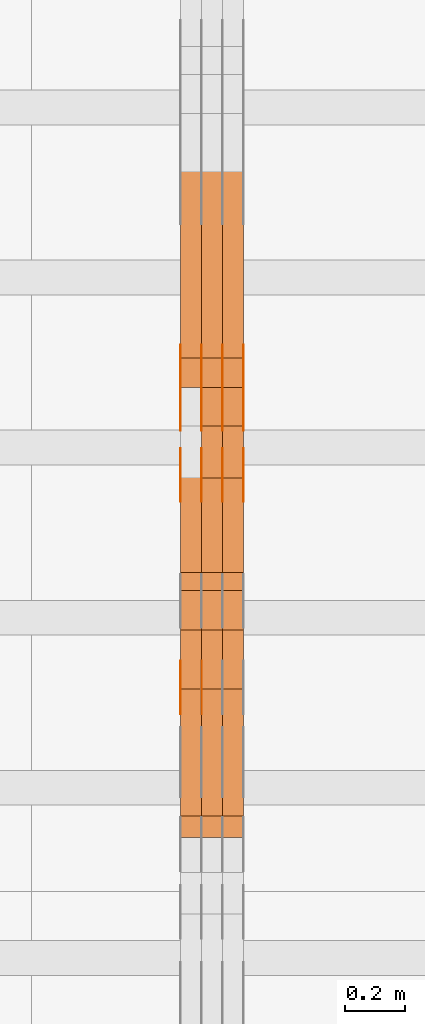
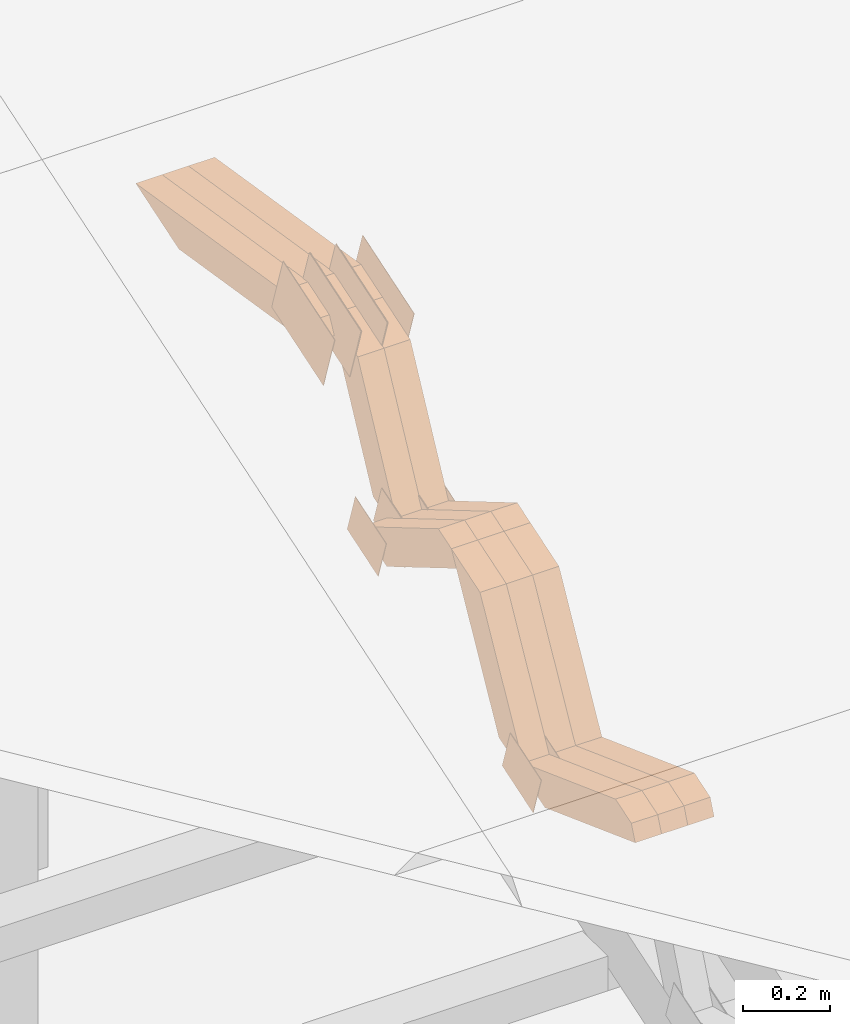
# One storey, part 117 of 385: 28 proxies.
"""IFC2X3 building model written with IfcOpenShell, lengths in millimetres."""

from ifc_helpers import new_model, entity, si_unit, converted_unit, derived_unit, direction, frame, origin, place, context, subcontext, project, spatial, polyline, outline, extrude, source, transform, mapped, material, type_object, type_shapes, element, save


model = new_model("IFC2X3")

# Units and contexts
model_context = context("Model", 3, precision=0.01, world=origin(), true_north=direction((6.12303176911189e-17, 1.0)))
body_context = subcontext(model_context, "Body", "Model", "MODEL_VIEW")
ifc_project = project(units=[si_unit("LENGTHUNIT", "METRE", prefix="MILLI"), si_unit("AREAUNIT", "SQUARE_METRE"), si_unit("VOLUMEUNIT", "CUBIC_METRE"), converted_unit("PLANEANGLEUNIT", "DEGREE", entity("IfcRatioMeasure", 0.0174532925199433), si_unit("PLANEANGLEUNIT", "RADIAN"), dimensions=[0, 0, 0, 0, 0, 0, 0]), si_unit("MASSUNIT", "GRAM", prefix="KILO"), derived_unit("MASSDENSITYUNIT", [(si_unit("MASSUNIT", "GRAM", prefix="KILO"), 1), (si_unit("LENGTHUNIT", "METRE"), -3)]), si_unit("TIMEUNIT", "SECOND"), si_unit("FREQUENCYUNIT", "HERTZ"), si_unit("THERMODYNAMICTEMPERATUREUNIT", "DEGREE_CELSIUS"), derived_unit("THERMALTRANSMITTANCEUNIT", [(si_unit("MASSUNIT", "GRAM", prefix="KILO"), 1), (si_unit("THERMODYNAMICTEMPERATUREUNIT", "KELVIN"), -1), (si_unit("TIMEUNIT", "SECOND"), -3)]), derived_unit("VOLUMETRICFLOWRATEUNIT", [(si_unit("LENGTHUNIT", "METRE"), 3), (si_unit("TIMEUNIT", "SECOND"), -1)]), si_unit("ELECTRICCURRENTUNIT", "AMPERE"), si_unit("ELECTRICVOLTAGEUNIT", "VOLT"), si_unit("POWERUNIT", "WATT"), si_unit("FORCEUNIT", "NEWTON", prefix="KILO"), si_unit("ILLUMINANCEUNIT", "LUX"), si_unit("LUMINOUSFLUXUNIT", "LUMEN"), si_unit("LUMINOUSINTENSITYUNIT", "CANDELA"), derived_unit("USERDEFINED", [(si_unit("MASSUNIT", "GRAM", prefix="KILO"), -1), (si_unit("LENGTHUNIT", "METRE"), -2), (si_unit("TIMEUNIT", "SECOND"), 3), (si_unit("LUMINOUSFLUXUNIT", "LUMEN"), 1)]), derived_unit("LINEARVELOCITYUNIT", [(si_unit("LENGTHUNIT", "METRE"), 1), (si_unit("TIMEUNIT", "SECOND"), -1)]), si_unit("PRESSUREUNIT", "PASCAL"), derived_unit("USERDEFINED", [(si_unit("LENGTHUNIT", "METRE"), -2), (si_unit("MASSUNIT", "GRAM", prefix="KILO"), 1), (si_unit("TIMEUNIT", "SECOND"), -2)])], contexts=[model_context])

# Site, building, storey
site_placement = place(None, origin())
site = spatial("IfcSite", under=ifc_project, at=site_placement, CompositionType="ELEMENT")
building_placement = place(site_placement, origin())
building = spatial("IfcBuilding", under=site, at=building_placement, CompositionType="ELEMENT")
storey_placement = place(building_placement, origin())
storey = spatial("IfcBuildingStorey", under=building, at=storey_placement, Name="Default", CompositionType="ELEMENT", Elevation=0.0)

# Proxies
ifc_material_1 = material(Name="IfcSurfaceStyle #244370")
building_element_proxy_type_1 = type_object("IfcBuildingElementProxyType", PredefinedType="NOTDEFINED", material=ifc_material_1)
shared_shape_1 = source(origin(), body_context, "Body", "SweptSolid", [
    extrude(outline(polyline([(-75.0008041947458, -59.9996998629349), (75.0007893252423, -59.9996998629349), (75.0008041947458, 59.9996998629349), (-75.0007893252423, 59.9996998629349), (-75.0008041947458, -59.9996998629349)])), frame((75.0008041947458, 60.0002282421692, 0.0), z_axis=(0.0, 0.0, 1.0), x_axis=(-1.0, 0.0, 0.0)), (0.0, 0.0, 1.0), 1.29999999999999),
])
type_shapes(building_element_proxy_type_1, [shared_shape_1])
proxy_1_placement = place(building_placement, frame((18246.3, 9291.048828125, 2194.94482421875), z_axis=(-1.0, 0.0, 0.0), x_axis=(0.0, 0.951056516295124, 0.309016994375039)))
element("IfcBuildingElementProxy", 1, at=proxy_1_placement, inside=storey, type_object=building_element_proxy_type_1, material=ifc_material_1, context=body_context, shape_type="MappedRepresentation", body=[
    mapped(shared_shape_1, transform((0.0, 0.0, 0.0), scale=1.0)),
])
ifc_material_2 = material(Name="IfcSurfaceStyle #244313")
building_element_proxy_type_2 = type_object("IfcBuildingElementProxyType", PredefinedType="NOTDEFINED", material=ifc_material_2)
shared_shape_2 = source(origin(), body_context, "Body", "SweptSolid", [
    extrude(outline(polyline([(-75.0008041947458, -59.9996998629349), (75.0007893252423, -59.9996998629349), (75.0008041947458, 59.9996998629349), (-75.0007893252423, 59.9996998629349), (-75.0008041947458, -59.9996998629349)])), frame((75.0008041947458, 60.0002282421692, 0.0), z_axis=(0.0, 0.0, 1.0), x_axis=(-1.0, 0.0, 0.0)), (0.0, 0.0, 1.0), 1.29999999999999),
])
type_shapes(building_element_proxy_type_2, [shared_shape_2])
proxy_2_placement = place(building_placement, frame((18175.0, 9291.048828125, 2194.94482421875), z_axis=(-1.0, 0.0, 0.0), x_axis=(0.0, 0.951056516295124, 0.309016994375039)))
element("IfcBuildingElementProxy", 2, at=proxy_2_placement, inside=storey, type_object=building_element_proxy_type_2, material=ifc_material_2, context=body_context, shape_type="MappedRepresentation", body=[
    mapped(shared_shape_2, transform((0.0, 0.0, 0.0), scale=1.0)),
])
ifc_material_3 = material(Name="IfcSurfaceStyle #244256")
building_element_proxy_type_3 = type_object("IfcBuildingElementProxyType", PredefinedType="NOTDEFINED", material=ifc_material_3)
shared_shape_3 = source(origin(), body_context, "Body", "SweptSolid", [
    extrude(outline(polyline([(-124.999432723313, -83.9999457831645), (125.000177551971, -83.9999457831645), (124.999395001513, 83.9999457831646), (-125.000139830171, 83.9999457831645), (-124.999432723313, -83.9999457831645)])), frame((125.000177551971, 84.0001194377192, 0.0), z_axis=(0.0, 0.0, 1.0), x_axis=(-1.0, 0.0, 0.0)), (0.0, 0.0, 1.0), 1.3),
])
type_shapes(building_element_proxy_type_3, [shared_shape_3])
proxy_3_placement = place(building_placement, frame((18386.3, 10242.0968435406, 2855.88278137571), z_axis=(-1.0, 0.0, 0.0), x_axis=(0.0, 0.951056516295154, 0.309016994374948)))
element("IfcBuildingElementProxy", 3, at=proxy_3_placement, inside=storey, type_object=building_element_proxy_type_3, material=ifc_material_3, context=body_context, shape_type="MappedRepresentation", body=[
    mapped(shared_shape_3, transform((0.0, 0.0, 0.0), scale=1.0)),
])
ifc_material_4 = material(Name="IfcSurfaceStyle #244199")
building_element_proxy_type_4 = type_object("IfcBuildingElementProxyType", PredefinedType="NOTDEFINED", material=ifc_material_4)
shared_shape_4 = source(origin(), body_context, "Body", "SweptSolid", [
    extrude(outline(polyline([(-124.999432723313, -83.9999457831645), (125.000177551971, -83.9999457831645), (124.999395001513, 83.9999457831646), (-125.000139830171, 83.9999457831645), (-124.999432723313, -83.9999457831645)])), frame((125.000177551971, 84.0001194377192, 0.0), z_axis=(0.0, 0.0, 1.0), x_axis=(-1.0, 0.0, 0.0)), (0.0, 0.0, 1.0), 1.3),
])
type_shapes(building_element_proxy_type_4, [shared_shape_4])
proxy_4_placement = place(building_placement, frame((18315.0, 10242.0968435406, 2855.88278137571), z_axis=(-1.0, 0.0, 0.0), x_axis=(0.0, 0.951056516295154, 0.309016994374948)))
element("IfcBuildingElementProxy", 4, at=proxy_4_placement, inside=storey, type_object=building_element_proxy_type_4, material=ifc_material_4, context=body_context, shape_type="MappedRepresentation", body=[
    mapped(shared_shape_4, transform((0.0, 0.0, 0.0), scale=1.0)),
])
ifc_material_5 = material(Name="IfcSurfaceStyle #244142")
building_element_proxy_type_5 = type_object("IfcBuildingElementProxyType", PredefinedType="NOTDEFINED", material=ifc_material_5)
shared_shape_5 = source(origin(), body_context, "Body", "SweptSolid", [
    extrude(outline(polyline([(-124.999432723313, -83.9999457831645), (125.000177551971, -83.9999457831645), (124.999395001513, 83.9999457831646), (-125.000139830171, 83.9999457831645), (-124.999432723313, -83.9999457831645)])), frame((125.000177551971, 84.0001194377192, 0.0), z_axis=(0.0, 0.0, 1.0), x_axis=(-1.0, 0.0, 0.0)), (0.0, 0.0, 1.0), 1.3),
])
type_shapes(building_element_proxy_type_5, [shared_shape_5])
proxy_5_placement = place(building_placement, frame((18316.3, 10242.0968435406, 2855.88278137571), z_axis=(-1.0, 0.0, 0.0), x_axis=(0.0, 0.951056516295154, 0.309016994374948)))
element("IfcBuildingElementProxy", 5, at=proxy_5_placement, inside=storey, type_object=building_element_proxy_type_5, material=ifc_material_5, context=body_context, shape_type="MappedRepresentation", body=[
    mapped(shared_shape_5, transform((0.0, 0.0, 0.0), scale=1.0)),
])
ifc_material_6 = material(Name="IfcSurfaceStyle #244085")
building_element_proxy_type_6 = type_object("IfcBuildingElementProxyType", PredefinedType="NOTDEFINED", material=ifc_material_6)
shared_shape_6 = source(origin(), body_context, "Body", "SweptSolid", [
    extrude(outline(polyline([(-124.999432723313, -83.9999457831645), (125.000177551971, -83.9999457831645), (124.999395001513, 83.9999457831646), (-125.000139830171, 83.9999457831645), (-124.999432723313, -83.9999457831645)])), frame((125.000177551971, 84.0001194377192, 0.0), z_axis=(0.0, 0.0, 1.0), x_axis=(-1.0, 0.0, 0.0)), (0.0, 0.0, 1.0), 1.29999999999998),
])
type_shapes(building_element_proxy_type_6, [shared_shape_6])
proxy_6_placement = place(building_placement, frame((18245.0, 10242.0968435406, 2855.88278137571), z_axis=(-1.0, 0.0, 0.0), x_axis=(0.0, 0.951056516295154, 0.309016994374948)))
element("IfcBuildingElementProxy", 6, at=proxy_6_placement, inside=storey, type_object=building_element_proxy_type_6, material=ifc_material_6, context=body_context, shape_type="MappedRepresentation", body=[
    mapped(shared_shape_6, transform((0.0, 0.0, 0.0), scale=1.0)),
])
ifc_material_7 = material(Name="IfcSurfaceStyle #244028")
building_element_proxy_type_7 = type_object("IfcBuildingElementProxyType", PredefinedType="NOTDEFINED", material=ifc_material_7)
shared_shape_7 = source(origin(), body_context, "Body", "SweptSolid", [
    extrude(outline(polyline([(-124.999432723313, -83.9999457831645), (125.000177551971, -83.9999457831645), (124.999395001513, 83.9999457831646), (-125.000139830171, 83.9999457831645), (-124.999432723313, -83.9999457831645)])), frame((125.000177551971, 84.0001194377192, 0.0), z_axis=(0.0, 0.0, 1.0), x_axis=(-1.0, 0.0, 0.0)), (0.0, 0.0, 1.0), 1.29999999999998),
])
type_shapes(building_element_proxy_type_7, [shared_shape_7])
proxy_7_placement = place(building_placement, frame((18246.3, 10242.0968435406, 2855.88278137571), z_axis=(-1.0, 0.0, 0.0), x_axis=(0.0, 0.951056516295154, 0.309016994374948)))
element("IfcBuildingElementProxy", 7, at=proxy_7_placement, inside=storey, type_object=building_element_proxy_type_7, material=ifc_material_7, context=body_context, shape_type="MappedRepresentation", body=[
    mapped(shared_shape_7, transform((0.0, 0.0, 0.0), scale=1.0)),
])
ifc_material_8 = material(Name="IfcSurfaceStyle #243971")
building_element_proxy_type_8 = type_object("IfcBuildingElementProxyType", PredefinedType="NOTDEFINED", material=ifc_material_8)
shared_shape_8 = source(origin(), body_context, "Body", "SweptSolid", [
    extrude(outline(polyline([(-124.999432723313, -83.9999457831645), (125.000177551971, -83.9999457831645), (124.999395001513, 83.9999457831646), (-125.000139830171, 83.9999457831645), (-124.999432723313, -83.9999457831645)])), frame((125.000177551971, 84.0001194377192, 0.0), z_axis=(0.0, 0.0, 1.0), x_axis=(-1.0, 0.0, 0.0)), (0.0, 0.0, 1.0), 1.29999999999998),
])
type_shapes(building_element_proxy_type_8, [shared_shape_8])
proxy_8_placement = place(building_placement, frame((18175.0, 10242.0968435406, 2855.88278137571), z_axis=(-1.0, 0.0, 0.0), x_axis=(0.0, 0.951056516295154, 0.309016994374948)))
element("IfcBuildingElementProxy", 8, at=proxy_8_placement, inside=storey, type_object=building_element_proxy_type_8, material=ifc_material_8, context=body_context, shape_type="MappedRepresentation", body=[
    mapped(shared_shape_8, transform((0.0, 0.0, 0.0), scale=1.0)),
])
ifc_material_9 = material(Name="IfcSurfaceStyle #242546")
building_element_proxy_type_9 = type_object("IfcBuildingElementProxyType", PredefinedType="NOTDEFINED", material=ifc_material_9)
shared_shape_9 = source(origin(), body_context, "Body", "SweptSolid", [
    extrude(outline(polyline([(-74.9998754286189, -60.0000016373433), (74.9998605591118, -60.0000016373433), (74.9998754286189, 60.0000016373433), (-74.9998605591118, 60.0000016373433), (-74.9998754286189, -60.0000016373433)])), frame((74.9999131819004, 60.0000016373433, 0.0), z_axis=(0.0, 0.0, 1.0), x_axis=(-1.0, 0.0, 0.0)), (0.0, 0.0, 1.0), 1.3),
])
type_shapes(building_element_proxy_type_9, [shared_shape_9])
proxy_9_placement = place(building_placement, frame((18386.3, 10004.8612689908, 2426.87628052724), z_axis=(-1.0, 0.0, 0.0), x_axis=(0.0, 0.951056516295124, 0.309016994375039)))
element("IfcBuildingElementProxy", 9, at=proxy_9_placement, inside=storey, type_object=building_element_proxy_type_9, material=ifc_material_9, context=body_context, shape_type="MappedRepresentation", body=[
    mapped(shared_shape_9, transform((0.0, 0.0, 0.0), scale=1.0)),
])
ifc_material_10 = material(Name="IfcSurfaceStyle #242489")
building_element_proxy_type_10 = type_object("IfcBuildingElementProxyType", PredefinedType="NOTDEFINED", material=ifc_material_10)
shared_shape_10 = source(origin(), body_context, "Body", "SweptSolid", [
    extrude(outline(polyline([(-74.9998754286189, -60.0000016373433), (74.9998605591118, -60.0000016373433), (74.9998754286189, 60.0000016373433), (-74.9998605591118, 60.0000016373433), (-74.9998754286189, -60.0000016373433)])), frame((74.9999131819004, 60.0000016373433, 0.0), z_axis=(0.0, 0.0, 1.0), x_axis=(-1.0, 0.0, 0.0)), (0.0, 0.0, 1.0), 1.3),
])
type_shapes(building_element_proxy_type_10, [shared_shape_10])
proxy_10_placement = place(building_placement, frame((18315.0, 10004.8612689908, 2426.87628052724), z_axis=(-1.0, 0.0, 0.0), x_axis=(0.0, 0.951056516295124, 0.309016994375039)))
element("IfcBuildingElementProxy", 10, at=proxy_10_placement, inside=storey, type_object=building_element_proxy_type_10, material=ifc_material_10, context=body_context, shape_type="MappedRepresentation", body=[
    mapped(shared_shape_10, transform((0.0, 0.0, 0.0), scale=1.0)),
])
ifc_material_11 = material(Name="IfcSurfaceStyle #242432")
building_element_proxy_type_11 = type_object("IfcBuildingElementProxyType", PredefinedType="NOTDEFINED", material=ifc_material_11)
shared_shape_11 = source(origin(), body_context, "Body", "SweptSolid", [
    extrude(outline(polyline([(-74.9998754286189, -60.0000016373433), (74.9998605591118, -60.0000016373433), (74.9998754286189, 60.0000016373433), (-74.9998605591118, 60.0000016373433), (-74.9998754286189, -60.0000016373433)])), frame((74.9999131819004, 60.0000016373433, 0.0), z_axis=(0.0, 0.0, 1.0), x_axis=(-1.0, 0.0, 0.0)), (0.0, 0.0, 1.0), 1.3),
])
type_shapes(building_element_proxy_type_11, [shared_shape_11])
proxy_11_placement = place(building_placement, frame((18316.3, 10004.8612689908, 2426.87628052724), z_axis=(-1.0, 0.0, 0.0), x_axis=(0.0, 0.951056516295124, 0.309016994375039)))
element("IfcBuildingElementProxy", 11, at=proxy_11_placement, inside=storey, type_object=building_element_proxy_type_11, material=ifc_material_11, context=body_context, shape_type="MappedRepresentation", body=[
    mapped(shared_shape_11, transform((0.0, 0.0, 0.0), scale=1.0)),
])
ifc_material_12 = material(Name="IfcSurfaceStyle #242375")
building_element_proxy_type_12 = type_object("IfcBuildingElementProxyType", PredefinedType="NOTDEFINED", material=ifc_material_12)
shared_shape_12 = source(origin(), body_context, "Body", "SweptSolid", [
    extrude(outline(polyline([(-74.9998754286189, -60.0000016373433), (74.9998605591118, -60.0000016373433), (74.9998754286189, 60.0000016373433), (-74.9998605591118, 60.0000016373433), (-74.9998754286189, -60.0000016373433)])), frame((74.9999131819004, 60.0000016373433, 0.0), z_axis=(0.0, 0.0, 1.0), x_axis=(-1.0, 0.0, 0.0)), (0.0, 0.0, 1.0), 1.29999999999999),
])
type_shapes(building_element_proxy_type_12, [shared_shape_12])
proxy_12_placement = place(building_placement, frame((18245.0, 10004.8612689908, 2426.87628052724), z_axis=(-1.0, 0.0, 0.0), x_axis=(0.0, 0.951056516295124, 0.309016994375039)))
element("IfcBuildingElementProxy", 12, at=proxy_12_placement, inside=storey, type_object=building_element_proxy_type_12, material=ifc_material_12, context=body_context, shape_type="MappedRepresentation", body=[
    mapped(shared_shape_12, transform((0.0, 0.0, 0.0), scale=1.0)),
])
ifc_material_13 = material(Name="IfcSurfaceStyle #242318")
building_element_proxy_type_13 = type_object("IfcBuildingElementProxyType", PredefinedType="NOTDEFINED", material=ifc_material_13)
shared_shape_13 = source(origin(), body_context, "Body", "SweptSolid", [
    extrude(outline(polyline([(-74.9998754286189, -60.0000016373433), (74.9998605591118, -60.0000016373433), (74.9998754286189, 60.0000016373433), (-74.9998605591118, 60.0000016373433), (-74.9998754286189, -60.0000016373433)])), frame((74.9999131819004, 60.0000016373433, 0.0), z_axis=(0.0, 0.0, 1.0), x_axis=(-1.0, 0.0, 0.0)), (0.0, 0.0, 1.0), 1.29999999999999),
])
type_shapes(building_element_proxy_type_13, [shared_shape_13])
proxy_13_placement = place(building_placement, frame((18246.3, 10004.8612689908, 2426.87628052724), z_axis=(-1.0, 0.0, 0.0), x_axis=(0.0, 0.951056516295124, 0.309016994375039)))
element("IfcBuildingElementProxy", 13, at=proxy_13_placement, inside=storey, type_object=building_element_proxy_type_13, material=ifc_material_13, context=body_context, shape_type="MappedRepresentation", body=[
    mapped(shared_shape_13, transform((0.0, 0.0, 0.0), scale=1.0)),
])
ifc_material_14 = material(Name="IfcSurfaceStyle #242261")
building_element_proxy_type_14 = type_object("IfcBuildingElementProxyType", PredefinedType="NOTDEFINED", material=ifc_material_14)
shared_shape_14 = source(origin(), body_context, "Body", "SweptSolid", [
    extrude(outline(polyline([(-74.9998754286189, -60.0000016373433), (74.9998605591118, -60.0000016373433), (74.9998754286189, 60.0000016373433), (-74.9998605591118, 60.0000016373433), (-74.9998754286189, -60.0000016373433)])), frame((74.9999131819004, 60.0000016373433, 0.0), z_axis=(0.0, 0.0, 1.0), x_axis=(-1.0, 0.0, 0.0)), (0.0, 0.0, 1.0), 1.29999999999999),
])
type_shapes(building_element_proxy_type_14, [shared_shape_14])
proxy_14_placement = place(building_placement, frame((18175.0, 10004.8612689908, 2426.87628052724), z_axis=(-1.0, 0.0, 0.0), x_axis=(0.0, 0.951056516295124, 0.309016994375039)))
element("IfcBuildingElementProxy", 14, at=proxy_14_placement, inside=storey, type_object=building_element_proxy_type_14, material=ifc_material_14, context=body_context, shape_type="MappedRepresentation", body=[
    mapped(shared_shape_14, transform((0.0, 0.0, 0.0), scale=1.0)),
])
ifc_material_15 = material(Name="IfcSurfaceStyle #222224")
building_element_proxy_type_15 = type_object("IfcBuildingElementProxyType", Name="T1-W5 222222", PredefinedType="NOTDEFINED", material=ifc_material_15)
shared_shape_15 = source(origin(), body_context, "Body", "SweptSolid", [
    extrude(outline(polyline([(-301.214270081322, -47.5000783565111), (303.980395954293, -47.5000783565111), (288.664123931657, 0.000197935560590153), (195.704076557203, 47.4999793887309), (-487.134326361831, 47.4999793887309), (-301.214270081322, -47.5000783565111)])), frame((303.980395954293, 47.5001815410909, 0.0), z_axis=(0.0, 0.0, 1.0), x_axis=(-1.0, 0.0, 0.0)), (0.0, 0.0, 1.0), 70.0),
])
type_shapes(building_element_proxy_type_15, [shared_shape_15])
proxy_15_placement = place(building_placement, frame((18385.0, 10379.2051671398, 2863.91176079486), z_axis=(-1.0, 0.0, 0.0), x_axis=(0.0, 0.987508363398486, -0.1575665961365)))
element("IfcBuildingElementProxy", 15, at=proxy_15_placement, inside=storey, type_object=building_element_proxy_type_15, material=ifc_material_15, Name="T1-W5", context=body_context, shape_type="MappedRepresentation", body=[
    mapped(shared_shape_15, transform((0.0, 0.0, 0.0), scale=1.0)),
])
ifc_material_16 = material(Name="IfcSurfaceStyle #222158")
building_element_proxy_type_16 = type_object("IfcBuildingElementProxyType", Name="T1-W5 222156", PredefinedType="NOTDEFINED", material=ifc_material_16)
shared_shape_16 = source(origin(), body_context, "Body", "SweptSolid", [
    extrude(outline(polyline([(-301.214270081322, -47.5000783565111), (303.980395954293, -47.5000783565111), (288.664123931657, 0.000197935560590153), (195.704076557203, 47.4999793887309), (-487.134326361831, 47.4999793887309), (-301.214270081322, -47.5000783565111)])), frame((303.980395954293, 47.5001815410909, 0.0), z_axis=(0.0, 0.0, 1.0), x_axis=(-1.0, 0.0, 0.0)), (0.0, 0.0, 1.0), 70.0),
])
type_shapes(building_element_proxy_type_16, [shared_shape_16])
proxy_16_placement = place(building_placement, frame((18315.0, 10379.2051671398, 2863.91176079486), z_axis=(-1.0, 0.0, 0.0), x_axis=(0.0, 0.987508363398486, -0.1575665961365)))
element("IfcBuildingElementProxy", 16, at=proxy_16_placement, inside=storey, type_object=building_element_proxy_type_16, material=ifc_material_16, Name="T1-W5", context=body_context, shape_type="MappedRepresentation", body=[
    mapped(shared_shape_16, transform((0.0, 0.0, 0.0), scale=1.0)),
])
ifc_material_17 = material(Name="IfcSurfaceStyle #222092")
building_element_proxy_type_17 = type_object("IfcBuildingElementProxyType", Name="T1-W5 222090", PredefinedType="NOTDEFINED", material=ifc_material_17)
shared_shape_17 = source(origin(), body_context, "Body", "SweptSolid", [
    extrude(outline(polyline([(-301.214270081322, -47.5000783565111), (303.980395954293, -47.5000783565111), (288.664123931657, 0.000197935560590153), (195.704076557203, 47.4999793887309), (-487.134326361831, 47.4999793887309), (-301.214270081322, -47.5000783565111)])), frame((303.980395954293, 47.5001815410909, 0.0), z_axis=(0.0, 0.0, 1.0), x_axis=(-1.0, 0.0, 0.0)), (0.0, 0.0, 1.0), 70.0),
])
type_shapes(building_element_proxy_type_17, [shared_shape_17])
proxy_17_placement = place(building_placement, frame((18245.0, 10379.2051671398, 2863.91176079486), z_axis=(-1.0, 0.0, 0.0), x_axis=(0.0, 0.987508363398486, -0.1575665961365)))
element("IfcBuildingElementProxy", 17, at=proxy_17_placement, inside=storey, type_object=building_element_proxy_type_17, material=ifc_material_17, Name="T1-W5", context=body_context, shape_type="MappedRepresentation", body=[
    mapped(shared_shape_17, transform((0.0, 0.0, 0.0), scale=1.0)),
])
ifc_material_18 = material(Name="IfcSurfaceStyle #221828")
building_element_proxy_type_18 = type_object("IfcBuildingElementProxyType", Name="T1-W37 221826", PredefinedType="NOTDEFINED", material=ifc_material_18)
shared_shape_18 = source(origin(), body_context, "Body", "SweptSolid", [
    extrude(outline(polyline([(111.787482004227, -179.289397746839), (245.990585035629, -179.289397746839), (-64.0177573255029, 131.410401861866), (-131.116409377007, 131.410958895698), (-162.643900337347, 95.757434736113), (111.787482004227, -179.289397746839)])), frame((185.635323570343, 47.5011799885346, 0.0), z_axis=(0.0, 0.0, 1.0), x_axis=(0.706316677358935, 0.707896003156279, 0.0)), (0.0, 0.0, 1.0), 70.0),
])
type_shapes(building_element_proxy_type_18, [shared_shape_18])
proxy_18_placement = place(building_placement, frame((18385.0, 10081.8581176196, 2424.08390440728), z_axis=(-1.0, 0.0, 0.0), x_axis=(0.0, 0.452995827831714, 0.891512635898707)))
element("IfcBuildingElementProxy", 18, at=proxy_18_placement, inside=storey, type_object=building_element_proxy_type_18, material=ifc_material_18, Name="T1-W37", context=body_context, shape_type="MappedRepresentation", body=[
    mapped(shared_shape_18, transform((0.0, 0.0, 0.0), scale=1.0)),
])
ifc_material_19 = material(Name="IfcSurfaceStyle #221762")
building_element_proxy_type_19 = type_object("IfcBuildingElementProxyType", Name="T1-W37 221760", PredefinedType="NOTDEFINED", material=ifc_material_19)
shared_shape_19 = source(origin(), body_context, "Body", "SweptSolid", [
    extrude(outline(polyline([(111.787482004227, -179.289397746839), (245.990585035629, -179.289397746839), (-64.0177573255029, 131.410401861866), (-131.116409377007, 131.410958895698), (-162.643900337347, 95.757434736113), (111.787482004227, -179.289397746839)])), frame((185.635323570343, 47.5011799885346, 0.0), z_axis=(0.0, 0.0, 1.0), x_axis=(0.706316677358935, 0.707896003156279, 0.0)), (0.0, 0.0, 1.0), 70.0),
])
type_shapes(building_element_proxy_type_19, [shared_shape_19])
proxy_19_placement = place(building_placement, frame((18315.0, 10081.8581176196, 2424.08390440728), z_axis=(-1.0, 0.0, 0.0), x_axis=(0.0, 0.452995827831714, 0.891512635898707)))
element("IfcBuildingElementProxy", 19, at=proxy_19_placement, inside=storey, type_object=building_element_proxy_type_19, material=ifc_material_19, Name="T1-W37", context=body_context, shape_type="MappedRepresentation", body=[
    mapped(shared_shape_19, transform((0.0, 0.0, 0.0), scale=1.0)),
])
ifc_material_20 = material(Name="IfcSurfaceStyle #221432")
building_element_proxy_type_20 = type_object("IfcBuildingElementProxyType", Name="T1-W43 221430", PredefinedType="NOTDEFINED", material=ifc_material_20)
shared_shape_20 = source(origin(), body_context, "Body", "SweptSolid", [
    extrude(outline(polyline([(-198.159905426436, -47.4999961988362), (173.155878681738, -47.4999961988362), (174.585865234707, -0.00038778214839239), (132.582704932703, 47.5001900899104), (-282.164543422712, 47.5001900899104), (-198.159905426436, -47.4999961988362)])), frame((174.585865234707, 47.5001900899104, 0.0), z_axis=(0.0, 0.0, 1.0), x_axis=(-1.0, 0.0, 0.0)), (0.0, 0.0, 1.0), 70.0),
])
type_shapes(building_element_proxy_type_20, [shared_shape_20])
proxy_20_placement = place(building_placement, frame((18385.0, 9730.71877771152, 2634.4881681647), z_axis=(-1.0, 0.0, 0.0), x_axis=(0.0, 0.861495156633645, -0.507765787639115)))
element("IfcBuildingElementProxy", 20, at=proxy_20_placement, inside=storey, type_object=building_element_proxy_type_20, material=ifc_material_20, Name="T1-W43", context=body_context, shape_type="MappedRepresentation", body=[
    mapped(shared_shape_20, transform((0.0, 0.0, 0.0), scale=1.0)),
])
ifc_material_21 = material(Name="IfcSurfaceStyle #221366")
building_element_proxy_type_21 = type_object("IfcBuildingElementProxyType", Name="T1-W43 221364", PredefinedType="NOTDEFINED", material=ifc_material_21)
shared_shape_21 = source(origin(), body_context, "Body", "SweptSolid", [
    extrude(outline(polyline([(-198.159905426436, -47.4999961988362), (173.155878681738, -47.4999961988362), (174.585865234707, -0.00038778214839239), (132.582704932703, 47.5001900899104), (-282.164543422712, 47.5001900899104), (-198.159905426436, -47.4999961988362)])), frame((174.585865234707, 47.5001900899104, 0.0), z_axis=(0.0, 0.0, 1.0), x_axis=(-1.0, 0.0, 0.0)), (0.0, 0.0, 1.0), 70.0),
])
type_shapes(building_element_proxy_type_21, [shared_shape_21])
proxy_21_placement = place(building_placement, frame((18315.0, 9730.71877771152, 2634.4881681647), z_axis=(-1.0, 0.0, 0.0), x_axis=(0.0, 0.861495156633645, -0.507765787639115)))
element("IfcBuildingElementProxy", 21, at=proxy_21_placement, inside=storey, type_object=building_element_proxy_type_21, material=ifc_material_21, Name="T1-W43", context=body_context, shape_type="MappedRepresentation", body=[
    mapped(shared_shape_21, transform((0.0, 0.0, 0.0), scale=1.0)),
])
ifc_material_22 = material(Name="IfcSurfaceStyle #221300")
building_element_proxy_type_22 = type_object("IfcBuildingElementProxyType", Name="T1-W43 221298", PredefinedType="NOTDEFINED", material=ifc_material_22)
shared_shape_22 = source(origin(), body_context, "Body", "SweptSolid", [
    extrude(outline(polyline([(-198.159905426436, -47.4999961988362), (173.155878681738, -47.4999961988362), (174.585865234707, -0.00038778214839239), (132.582704932703, 47.5001900899104), (-282.164543422712, 47.5001900899104), (-198.159905426436, -47.4999961988362)])), frame((174.585865234707, 47.5001900899104, 0.0), z_axis=(0.0, 0.0, 1.0), x_axis=(-1.0, 0.0, 0.0)), (0.0, 0.0, 1.0), 70.0),
])
type_shapes(building_element_proxy_type_22, [shared_shape_22])
proxy_22_placement = place(building_placement, frame((18245.0, 9730.71877771152, 2634.4881681647), z_axis=(-1.0, 0.0, 0.0), x_axis=(0.0, 0.861495156633645, -0.507765787639115)))
element("IfcBuildingElementProxy", 22, at=proxy_22_placement, inside=storey, type_object=building_element_proxy_type_22, material=ifc_material_22, Name="T1-W43", context=body_context, shape_type="MappedRepresentation", body=[
    mapped(shared_shape_22, transform((0.0, 0.0, 0.0), scale=1.0)),
])
ifc_material_23 = material(Name="IfcSurfaceStyle #221036")
building_element_proxy_type_23 = type_object("IfcBuildingElementProxyType", Name="T1-W33 221034", PredefinedType="NOTDEFINED", material=ifc_material_23)
shared_shape_23 = source(origin(), body_context, "Body", "SweptSolid", [
    extrude(outline(polyline([(-314.173070820175, -47.4997758466969), (139.635944117881, -47.4997758466969), (190.204920608233, 0.000348187720347082), (197.369205310989, 47.5001702328475), (-213.036999216928, 47.4990332728259), (-314.173070820175, -47.4997758466969)])), frame((197.369205310989, 47.5001702328475, 0.0), z_axis=(0.0, 0.0, 1.0), x_axis=(-1.0, 0.0, 0.0)), (0.0, 0.0, 1.0), 70.0),
])
type_shapes(building_element_proxy_type_23, [shared_shape_23])
proxy_23_placement = place(building_placement, frame((18385.0, 9376.96875, 2191.01977539063), z_axis=(-1.0, 0.0, 0.0), x_axis=(0.0, 0.481632628948835, 0.876373214293907)))
element("IfcBuildingElementProxy", 23, at=proxy_23_placement, inside=storey, type_object=building_element_proxy_type_23, material=ifc_material_23, Name="T1-W33", context=body_context, shape_type="MappedRepresentation", body=[
    mapped(shared_shape_23, transform((0.0, 0.0, 0.0), scale=1.0)),
])
ifc_material_24 = material(Name="IfcSurfaceStyle #220970")
building_element_proxy_type_24 = type_object("IfcBuildingElementProxyType", Name="T1-W33 220968", PredefinedType="NOTDEFINED", material=ifc_material_24)
shared_shape_24 = source(origin(), body_context, "Body", "SweptSolid", [
    extrude(outline(polyline([(-314.173070820175, -47.4997758466969), (139.635944117881, -47.4997758466969), (190.204920608233, 0.000348187720347082), (197.369205310989, 47.5001702328475), (-213.036999216928, 47.4990332728259), (-314.173070820175, -47.4997758466969)])), frame((197.369205310989, 47.5001702328475, 0.0), z_axis=(0.0, 0.0, 1.0), x_axis=(-1.0, 0.0, 0.0)), (0.0, 0.0, 1.0), 70.0),
])
type_shapes(building_element_proxy_type_24, [shared_shape_24])
proxy_24_placement = place(building_placement, frame((18315.0, 9376.96875, 2191.01977539063), z_axis=(-1.0, 0.0, 0.0), x_axis=(0.0, 0.481632628948835, 0.876373214293907)))
element("IfcBuildingElementProxy", 24, at=proxy_24_placement, inside=storey, type_object=building_element_proxy_type_24, material=ifc_material_24, Name="T1-W33", context=body_context, shape_type="MappedRepresentation", body=[
    mapped(shared_shape_24, transform((0.0, 0.0, 0.0), scale=1.0)),
])
ifc_material_25 = material(Name="IfcSurfaceStyle #220904")
building_element_proxy_type_25 = type_object("IfcBuildingElementProxyType", Name="T1-W33 220902", PredefinedType="NOTDEFINED", material=ifc_material_25)
shared_shape_25 = source(origin(), body_context, "Body", "SweptSolid", [
    extrude(outline(polyline([(-314.173070820175, -47.4997758466969), (139.635944117881, -47.4997758466969), (190.204920608233, 0.000348187720347082), (197.369205310989, 47.5001702328475), (-213.036999216928, 47.4990332728259), (-314.173070820175, -47.4997758466969)])), frame((197.369205310989, 47.5001702328475, 0.0), z_axis=(0.0, 0.0, 1.0), x_axis=(-1.0, 0.0, 0.0)), (0.0, 0.0, 1.0), 70.0),
])
type_shapes(building_element_proxy_type_25, [shared_shape_25])
proxy_25_placement = place(building_placement, frame((18245.0, 9376.96875, 2191.01977539063), z_axis=(-1.0, 0.0, 0.0), x_axis=(0.0, 0.481632628948835, 0.876373214293907)))
element("IfcBuildingElementProxy", 25, at=proxy_25_placement, inside=storey, type_object=building_element_proxy_type_25, material=ifc_material_25, Name="T1-W33", context=body_context, shape_type="MappedRepresentation", body=[
    mapped(shared_shape_25, transform((0.0, 0.0, 0.0), scale=1.0)),
])
ifc_material_26 = material(Name="IfcSurfaceStyle #220640")
building_element_proxy_type_26 = type_object("IfcBuildingElementProxyType", Name="T1-W25 220638", PredefinedType="NOTDEFINED", material=ifc_material_26)
shared_shape_26 = source(origin(), body_context, "Body", "SweptSolid", [
    extrude(outline(polyline([(-229.232772462784, -47.5001671709529), (214.075939394384, -47.5001671709529), (212.688957821661, -0.000141058964427199), (152.358910178478, 47.5002377004352), (-349.891034931738, 47.5002377004352), (-229.232772462784, -47.5001671709529)])), frame((214.075939394384, 47.5002377004352, 0.0), z_axis=(0.0, 0.0, 1.0), x_axis=(-1.0, 0.0, 0.0)), (0.0, 0.0, 1.0), 70.0),
])
type_shapes(building_element_proxy_type_26, [shared_shape_26])
proxy_26_placement = place(building_placement, frame((18385.0, 8892.81895960242, 2369.29665807578), z_axis=(-1.0, 0.0, 0.0), x_axis=(0.0, 0.938402514401222, -0.345544094097213)))
element("IfcBuildingElementProxy", 26, at=proxy_26_placement, inside=storey, type_object=building_element_proxy_type_26, material=ifc_material_26, Name="T1-W25", context=body_context, shape_type="MappedRepresentation", body=[
    mapped(shared_shape_26, transform((0.0, 0.0, 0.0), scale=1.0)),
])
ifc_material_27 = material(Name="IfcSurfaceStyle #220574")
building_element_proxy_type_27 = type_object("IfcBuildingElementProxyType", Name="T1-W25 220572", PredefinedType="NOTDEFINED", material=ifc_material_27)
shared_shape_27 = source(origin(), body_context, "Body", "SweptSolid", [
    extrude(outline(polyline([(-229.232772462784, -47.5001671709529), (214.075939394384, -47.5001671709529), (212.688957821661, -0.000141058964427199), (152.358910178478, 47.5002377004352), (-349.891034931738, 47.5002377004352), (-229.232772462784, -47.5001671709529)])), frame((214.075939394384, 47.5002377004352, 0.0), z_axis=(0.0, 0.0, 1.0), x_axis=(-1.0, 0.0, 0.0)), (0.0, 0.0, 1.0), 70.0),
])
type_shapes(building_element_proxy_type_27, [shared_shape_27])
proxy_27_placement = place(building_placement, frame((18315.0, 8892.81895960242, 2369.29665807578), z_axis=(-1.0, 0.0, 0.0), x_axis=(0.0, 0.938402514401222, -0.345544094097213)))
element("IfcBuildingElementProxy", 27, at=proxy_27_placement, inside=storey, type_object=building_element_proxy_type_27, material=ifc_material_27, Name="T1-W25", context=body_context, shape_type="MappedRepresentation", body=[
    mapped(shared_shape_27, transform((0.0, 0.0, 0.0), scale=1.0)),
])
ifc_material_28 = material(Name="IfcSurfaceStyle #220508")
building_element_proxy_type_28 = type_object("IfcBuildingElementProxyType", Name="T1-W25 220506", PredefinedType="NOTDEFINED", material=ifc_material_28)
shared_shape_28 = source(origin(), body_context, "Body", "SweptSolid", [
    extrude(outline(polyline([(-229.232772462784, -47.5001671709529), (214.075939394384, -47.5001671709529), (212.688957821661, -0.000141058964427199), (152.358910178478, 47.5002377004352), (-349.891034931738, 47.5002377004352), (-229.232772462784, -47.5001671709529)])), frame((214.075939394384, 47.5002377004352, 0.0), z_axis=(0.0, 0.0, 1.0), x_axis=(-1.0, 0.0, 0.0)), (0.0, 0.0, 1.0), 70.0),
])
type_shapes(building_element_proxy_type_28, [shared_shape_28])
proxy_28_placement = place(building_placement, frame((18245.0, 8892.81895960242, 2369.29665807578), z_axis=(-1.0, 0.0, 0.0), x_axis=(0.0, 0.938402514401222, -0.345544094097213)))
element("IfcBuildingElementProxy", 28, at=proxy_28_placement, inside=storey, type_object=building_element_proxy_type_28, material=ifc_material_28, Name="T1-W25", context=body_context, shape_type="MappedRepresentation", body=[
    mapped(shared_shape_28, transform((0.0, 0.0, 0.0), scale=1.0)),
])

save(model, "model.ifc")
